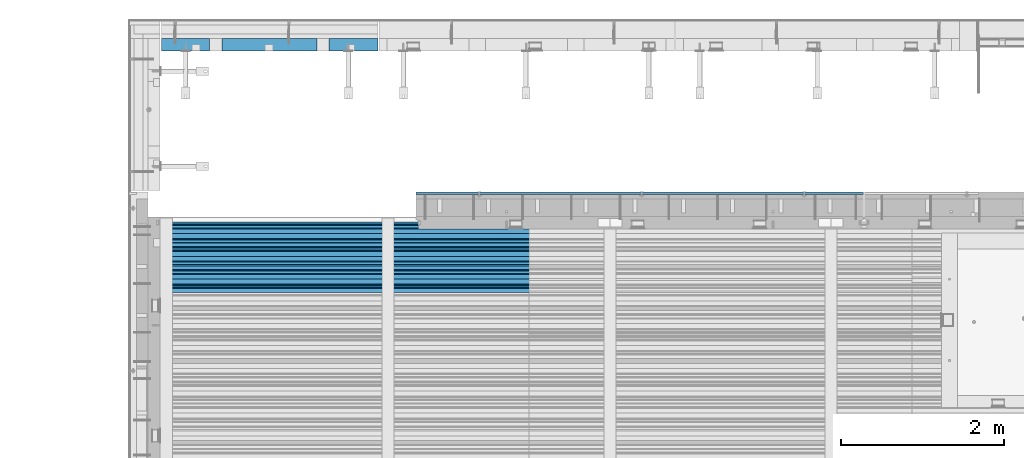
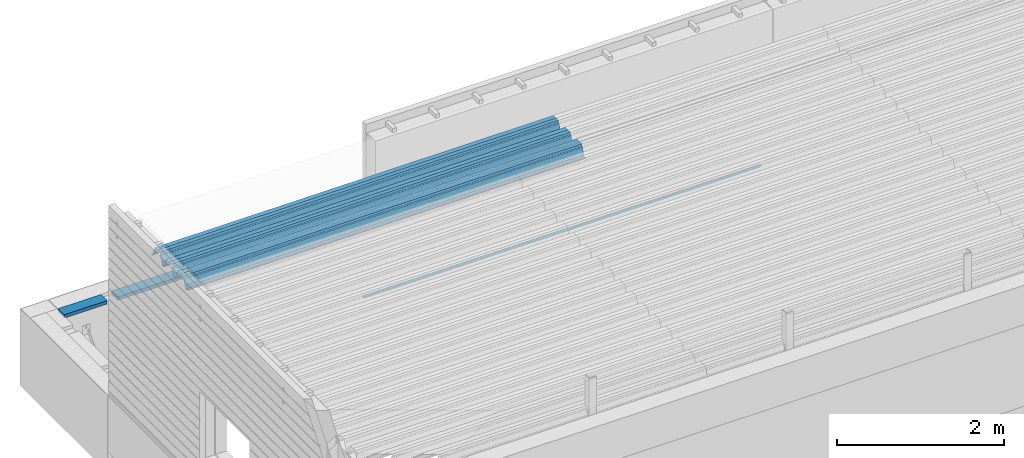
# One storey, part 35 of 153: 3 beams, 3 elements without a shape of their own.
"""IFC2X3 building model written with IfcOpenShell, lengths in millimetres."""

import ifcopenshell
import ifcopenshell.guid

model = None  # the IFC model being written
_history = None  # IfcOwnerHistory: only IFC2X3 demands one
_inside = {}  # id of a spatial element -> (the spatial element, [elements in it])
_under = {}  # id of a project, library or spatial element -> (it, [spatial elements below it])
_declared = {}  # id of a project -> (the project, [libraries it declares])
_typed = {}  # id of a type object -> (the type object, [elements of that type])
_made_of = {}  # id of a material, layer set ... -> (it, [elements and type objects made of it])


def new_model(schema):
    """Start an empty IFC model of exactly this schema.

    Asked for "IFC4X3", IfcOpenShell would pick the latest addendum, in which some entities
    have other attributes; the version numbers below select the first issue.
    IFC2X3 requires an IfcOwnerHistory on every rooted entity: one is made here for all.
    """
    global model, _history
    if schema == "IFC4X3":
        model = ifcopenshell.file(schema_version=(4, 3, 0, 0))
    else:
        model = ifcopenshell.file(schema=schema)
    _inside.clear()
    _under.clear()
    _declared.clear()
    _typed.clear()
    _made_of.clear()
    _history = None
    if model.schema == "IFC2X3":
        org = make("IfcOrganization", Name="unknown")
        user = make(
            "IfcPersonAndOrganization",
            ThePerson=make("IfcPerson", FamilyName="unknown"),
            TheOrganization=org,
        )
        app = make(
            "IfcApplication",
            ApplicationDeveloper=org,
            Version="unknown",
            ApplicationFullName="unknown",
            ApplicationIdentifier="unknown",
        )
        _history = make(
            "IfcOwnerHistory",
            OwningUser=user,
            OwningApplication=app,
            ChangeAction="ADDED",
            CreationDate=0,
        )
    return model


def make(cls, **values):
    """One entity of the class cls with the attributes given. An attribute that is None is left unset."""
    return model.create_entity(
        cls, **{name: value for name, value in values.items() if value is not None}
    )


def rooted(cls, **values):
    """An entity with a GlobalId (a new one), such as an element, a storey or a relation."""
    return make(cls, GlobalId=ifcopenshell.guid.new(), OwnerHistory=_history, **values)


def si_unit(unit_type, name, prefix=None):
    """IfcSIUnit, for example si_unit("LENGTHUNIT", "METRE", prefix="MILLI")."""
    return make("IfcSIUnit", UnitType=unit_type, Prefix=prefix, Name=name)


def assignment(units):
    """IfcUnitAssignment: the units of a project."""
    return None if units is None else make("IfcUnitAssignment", Units=units)


def point(xyz):
    """IfcCartesianPoint."""
    return None if xyz is None else make("IfcCartesianPoint", Coordinates=xyz)


def direction(xyz):
    """IfcDirection."""
    return None if xyz is None else make("IfcDirection", DirectionRatios=xyz)


def frame(location, z_axis=None, x_axis=None):
    """IfcAxis2Placement3D, a coordinate frame: its origin and axes. An axis left out is left unset."""
    return make(
        "IfcAxis2Placement3D",
        Location=point(location),
        Axis=direction(z_axis),
        RefDirection=direction(x_axis),
    )


def origin_with_axes():
    """The frame at (0, 0, 0) with the z axis (0, 0, 1) and the x axis (1, 0, 0) written out."""
    return frame((0.0, 0.0, 0.0), z_axis=(0.0, 0.0, 1.0), x_axis=(1.0, 0.0, 0.0))


def place(relative_to, where):
    """IfcLocalPlacement: puts the frame where relative to a parent placement (None: the world)."""
    return make(
        "IfcLocalPlacement", PlacementRelTo=relative_to, RelativePlacement=where
    )


def context(
    kind, dimensions, precision=None, world=None, true_north=None, identifier=None
):
    """IfcGeometricRepresentationContext, for example the 3D "Model" context."""
    return make(
        "IfcGeometricRepresentationContext",
        ContextIdentifier=identifier,
        ContextType=kind,
        CoordinateSpaceDimension=dimensions,
        Precision=precision,
        WorldCoordinateSystem=world,
        TrueNorth=true_north,
    )


def subcontext(parent, identifier, kind, view, scale=None):
    """IfcGeometricRepresentationSubContext, for example "Body" below "Model"."""
    return make(
        "IfcGeometricRepresentationSubContext",
        ContextIdentifier=identifier,
        ContextType=kind,
        ParentContext=parent,
        TargetScale=scale,
        TargetView=view,
    )


def project(units=None, contexts=None):
    """IfcProject with its units and contexts."""
    return rooted(
        "IfcProject",
        Name="project",
        RepresentationContexts=contexts,
        UnitsInContext=assignment(units),
    )


def spatial(cls, under=None, at=None, **own):
    """A site, building, storey or space (cls), placed at a placement, below another one or the project."""
    s = rooted(cls, ObjectPlacement=at, **own)
    if under is not None:
        _under.setdefault(under.id(), (under, []))[1].append(s)
    return s


def faces_of(points, faces, orient=None, outer=None):
    """IfcFace entities. A face is a list of loops; a loop is a list of indices into points, from 0.

    orient and outer hold one flag for each loop. By default every Orientation is true, the
    first loop of a face is its IfcFaceOuterBound and the others are IfcFaceBound.
    """
    made = []
    for i, loops in enumerate(faces):
        bounds = []
        for j, loop in enumerate(loops):
            is_outer = j == 0 if outer is None else outer[i][j]
            bounds.append(
                make(
                    "IfcFaceOuterBound" if is_outer else "IfcFaceBound",
                    Bound=make("IfcPolyLoop", Polygon=[points[k] for k in loop]),
                    Orientation=True if orient is None else orient[i][j],
                )
            )
        made.append(make("IfcFace", Bounds=bounds))
    return made


def faceted_brep(points, faces, orient=None, outer=None, voids=None):
    """IfcFacetedBrep: a solid bounded by flat faces; with voids (closed shells), ...WithVoids."""
    shared = [point(p) for p in points]
    hull = make("IfcClosedShell", CfsFaces=faces_of(shared, faces, orient, outer))
    if voids is None:
        return make("IfcFacetedBrep", Outer=hull)
    return make(
        "IfcFacetedBrepWithVoids",
        Outer=hull,
        Voids=[
            make(cls, CfsFaces=faces_of(shared, fs, o, b)) for cls, fs, o, b in voids
        ],
    )


def shape(context_of_items, identifier, shape_type, items):
    """IfcShapeRepresentation: the items that make up one representation, for example the "Body"."""
    return make(
        "IfcShapeRepresentation",
        ContextOfItems=context_of_items,
        RepresentationIdentifier=identifier,
        RepresentationType=shape_type,
        Items=items,
    )


def material(Name=None, Category=None):
    """IfcMaterial."""
    return make("IfcMaterial", Name=Name, Category=Category)


def made_of(thing, what):
    """Note that an element or type object is made of a material, layer set ...; save() writes the relation."""
    if what is not None:
        _made_of.setdefault(what.id(), (what, []))[1].append(thing)
    return thing


def type_object(cls, material=None, **own):
    """A type object (cls), such as IfcWallType, which elements share."""
    return made_of(rooted(cls, **own), material)


def element(
    cls,
    number,
    at=None,
    inside=None,
    cuts=None,
    type_object=None,
    material=None,
    context=None,
    identifier="Body",
    shape_type=None,
    held_by="IfcProductDefinitionShape",
    body=None,
    shapes=None,
    **own,
):
    """One element of the class cls, such as IfcWall. Its Tag is "e" and its number.

    at: its placement. inside: the storey or other place that contains it. cuts: it is an
    opening in that element (IfcRelVoidsElement). A single representation is given by context,
    identifier, shape_type and body (its items); several are given by shapes. held_by: the class
    of the entity that holds the representations. save() writes the other relations.
    """
    e = rooted(cls, Tag="e%d" % number, ObjectPlacement=at, **own)
    if body is not None:
        shapes = [shape(context, identifier, shape_type, body)]
    if shapes is not None:
        e.Representation = make(held_by, Representations=shapes)
    if inside is not None:
        _inside.setdefault(inside.id(), (inside, []))[1].append(e)
    if cuts is not None:
        rooted(
            "IfcRelVoidsElement", RelatingBuildingElement=cuts, RelatedOpeningElement=e
        )
    if type_object is not None:
        _typed.setdefault(type_object.id(), (type_object, []))[1].append(e)
    return made_of(e, material)


def aggregate(whole, parts):
    """IfcRelAggregates: a whole, such as a stair, and the parts it consists of."""
    return rooted("IfcRelAggregates", RelatingObject=whole, RelatedObjects=parts)


def save(model, path):
    """Write the relations noted so far, then the file.

    IfcRelAggregates (storeys below a building ...), IfcRelContainedInSpatialStructure (elements
    in a storey), IfcRelDefinesByType, IfcRelAssociatesMaterial and IfcRelDeclares: one each for
    every whole, place, type object, material and project.
    """
    for whole, parts in _under.values():
        aggregate(whole, parts)
    for where, things in _inside.values():
        rooted(
            "IfcRelContainedInSpatialStructure",
            RelatedElements=things,
            RelatingStructure=where,
        )
    for kind, things in _typed.values():
        rooted("IfcRelDefinesByType", RelatedObjects=things, RelatingType=kind)
    for what, things in _made_of.values():
        rooted("IfcRelAssociatesMaterial", RelatedObjects=things, RelatingMaterial=what)
    for by, libraries in _declared.values():
        rooted("IfcRelDeclares", RelatingContext=by, RelatedDefinitions=libraries)
    model.write(path)


model = new_model("IFC2X3")

# Units and contexts
model_context = context("Model", 3, precision=1e-05, world=origin_with_axes())
body_context = subcontext(model_context, "Body", "Model", "MODEL_VIEW")
ifc_project = project(units=[si_unit("LENGTHUNIT", "METRE", prefix="MILLI"), si_unit("AREAUNIT", "SQUARE_METRE"), si_unit("VOLUMEUNIT", "CUBIC_METRE"), si_unit("MASSUNIT", "GRAM", prefix="KILO"), si_unit("TIMEUNIT", "SECOND"), si_unit("PLANEANGLEUNIT", "RADIAN"), si_unit("SOLIDANGLEUNIT", "STERADIAN"), si_unit("THERMODYNAMICTEMPERATUREUNIT", "DEGREE_CELSIUS"), si_unit("LUMINOUSINTENSITYUNIT", "LUMEN")], contexts=[model_context])

# Site, building, storey
site_placement = place(None, origin_with_axes())
site = spatial("IfcSite", under=ifc_project, at=site_placement, CompositionType="ELEMENT")
building_placement = place(site_placement, origin_with_axes())
building = spatial("IfcBuilding", under=site, at=building_placement, CompositionType="ELEMENT")
storey_placement = place(building_placement, origin_with_axes())
storey = spatial("IfcBuildingStorey", under=building, at=storey_placement, Name="8", CompositionType="ELEMENT", Elevation=0.0)

# Assembly, beam
assembly_1_placement = place(storey_placement, origin_with_axes())
assembly_1 = element("IfcElementAssembly", 1, at=assembly_1_placement, inside=storey, AssemblyPlace="NOTDEFINED", PredefinedType="REINFORCEMENT_UNIT")
ifc_material_1 = material(Name="TIMBER")
beam_type_1 = type_object("IfcBeamType", PredefinedType="NOTDEFINED")
beam_1_placement = place(assembly_1_placement, frame((8015.0, 22695.0, 103545.0), z_axis=(0.0, 0.0, 1.0), x_axis=(1.0, 0.0, 0.0)))
beam_1 = element("IfcBeam", 2, at=beam_1_placement, type_object=beam_type_1, material=ifc_material_1, context=body_context, shape_type="Brep", body=[
    faceted_brep([(0.0, -75.0, -25.0), (1.81898940354586e-12, -75.0000000000009, 25.0), (1.81898940354586e-12, 75.0, 25.0), (0.0, 75.0, -25.0), (593.999676343074, -75.0, -25.0), (593.999676343074, -75.0, 25.0), (593.999640793072, 74.9998429442203, 25.0), (593.999640793072, 75.0, -25.0), (2063.99964079282, 74.9998784942218, 25.0), (2063.99964079282, 75.0, -25.0), (2063.99967634307, -75.0, -25.0), (2063.99967634307, -75.0, 25.0), (2662.5, -75.0, 25.0), (2662.5, -75.0, -25.0), (2662.5, 75.0, -25.0), (2662.5, 75.0, 25.0), (1913.99964079307, 74.9998429442203, 25.0), (1913.99967634307, -75.0, 25.0), (1913.99967634307, -75.0, -25.0), (1913.99964079307, 75.0, -25.0), (743.999640792823, 74.9998784942218, 25.0), (743.999640792823, 75.0, -25.0), (743.999676343068, -75.0, -25.0), (743.999676343068, -75.0, 25.0)], [[[0, 1, 2, 3]], [[1, 0, 4, 5]], [[2, 1, 5, 6]], [[3, 2, 6, 7]], [[0, 3, 7, 4]], [[6, 5, 4, 7]], [[8, 9, 10, 11]], [[12, 13, 14, 15]], [[12, 15, 8, 11]], [[13, 12, 11, 10]], [[14, 13, 10, 9]], [[15, 14, 9, 8]], [[16, 17, 18, 19]], [[20, 21, 22, 23]], [[21, 20, 16, 19]], [[22, 21, 19, 18]], [[23, 22, 18, 17]], [[20, 23, 17, 16]]]),
])
aggregate(assembly_1, [beam_1])

assembly_2_placement = place(storey_placement, origin_with_axes())
assembly_2 = element("IfcElementAssembly", 3, at=assembly_2_placement, inside=storey, AssemblyPlace="NOTDEFINED", PredefinedType="REINFORCEMENT_UNIT")
ifc_material_2 = material(Name="TIMBER/T24")
beam_type_2 = type_object("IfcBeamType", PredefinedType="NOTDEFINED")
beam_2_placement = place(assembly_2_placement, frame((11147.5, 20867.5, 103805.0), z_axis=(0.0, 1.0, 0.0), x_axis=(1.0, 0.0, 0.0)))
beam_2 = element("IfcBeam", 4, at=beam_2_placement, type_object=beam_type_2, material=ifc_material_2, context=body_context, shape_type="Brep", body=[
    faceted_brep([(5505.0, -6.35918695479631e-09, 12.4999999935681), (1.45519152283669e-11, -3.63797880709171e-12, 12.4999999999964), (0.0, -25.0, -12.5), (5505.0, -25.0, -12.5), (0.0, 25.0, -12.5), (0.0, 25.0, 12.5), (5505.0, 25.0, 12.5), (5505.0, 25.0, -12.5)], [[[0, 1, 2, 3]], [[4, 5, 6, 7]], [[7, 6, 0, 3]], [[4, 7, 3, 2]], [[5, 4, 2, 1]], [[6, 5, 1, 0]]]),
])
aggregate(assembly_2, [beam_2])

assembly_3_placement = place(storey_placement, origin_with_axes())
assembly_3 = element("IfcElementAssembly", 5, at=assembly_3_placement, inside=storey, Name="Steel Assembly", AssemblyPlace="NOTDEFINED", PredefinedType="RIGID_FRAME")
ifc_material_3 = material(Name="STEEL/S355J2")
beam_type_3 = type_object("IfcBeamType", Name="W", PredefinedType="NOTDEFINED")
beam_3_placement = place(assembly_3_placement, frame((13534.9999999929, 20081.9521353056, 105808.609793062), z_axis=(0.0, -0.0124990270013869, 0.999921884110963), x_axis=(-1.0, 3.00000001838171e-08, 0.0)))
beam_3 = element("IfcBeam", 6, at=beam_3_placement, type_object=beam_type_3, material=ifc_material_3, ObjectType="W", context=body_context, shape_type="Brep", body=[
    faceted_brep([(0.0, -412.839996337891, -77.0100021362159), (0.0, -409.160003662109, -77.0100021362014), (5530.0, -409.160003662109, -77.0100021362014), (5530.0, -412.839996337891, -77.0100021362159), (0.0, -408.070007324222, -73.4800033569045), (5530.0, -408.070007324222, -73.4800033569045), (0.0, -400.339996337894, -48.0600013732619), (5530.0, -400.339996337894, -48.0600013732619), (0.0, -399.459991455082, -46.5600013732619), (5530.0, -399.459991455082, -46.5600013732619), (0.0, -390.329986572269, -36.5499992370314), (5530.0, -390.329986572269, -36.5499992370314), (0.0, -389.19000244141, -34.6300010680861), (5530.0, -389.19000244141, -34.6300010680861), (0.0, -367.820007324222, 35.3400001526024), (5530.0, -367.820007324222, 35.3400001526024), (0.0, -366.989990234379, 36.8499984741502), (5530.0, -366.989990234379, 36.8499984741502), (0.0, -357.809997558597, 46.8600006103807), (5530.0, -357.809997558597, 46.8600006103807), (0.0, -356.720001220707, 48.7700004577782), (5530.0, -356.720001220707, 48.7700004577782), (0.0, -349.309997558594, 73.1500015258935), (5530.0, -349.309997558594, 73.1500015258935), (0.0, -347.850006103516, 75.2300033569481), (5530.0, -347.850006103516, 75.2300033569481), (0.0, -345.470001220707, 76.010002136245), (5530.0, -345.470001220707, 76.010002136245), (0.0, -305.480010986332, 76.010002136245), (5530.0, -305.480010986332, 76.010002136245), (0.0, -304.279998779301, 75.8000030517578), (5530.0, -304.279998779301, 75.8000030517578), (0.0, -291.679992675785, 71.6999969482567), (5530.0, -291.679992675785, 71.6999969482567), (0.0, -290.179992675789, 71.2300033569481), (5530.0, -290.179992675789, 71.2300033569481), (0.0, -288.720001220707, 71.6999969482567), (5530.0, -288.720001220707, 71.6999969482567), (0.0, -276.119995117191, 75.8000030517869), (5530.0, -276.119995117191, 75.8000030517869), (0.0, -274.929992675785, 76.010002136245), (5530.0, -274.929992675785, 76.010002136245), (0.0, -234.94000244141, 76.010002136245), (5530.0, -234.94000244141, 76.010002136245), (0.0, -232.550003051758, 75.2300033569627), (5530.0, -232.550003051758, 75.2300033569627), (0.0, -231.100006103519, 73.1500015258935), (5530.0, -231.100006103519, 73.1500015258935), (0.0, -223.679992675785, 48.7700004577782), (5530.0, -223.679992675785, 48.7700004577782), (0.0, -222.589996337894, 46.8600006103661), (5530.0, -222.589996337894, 46.8600006103661), (0.0, -213.410003662113, 36.8499984741502), (5530.0, -213.410003662113, 36.8499984741502), (0.0, -212.529998779301, 35.3400001526024), (5530.0, -212.529998779301, 35.3400001526024), (0.0, -191.160003662109, -34.6300010681007), (5530.0, -191.160003662109, -34.6300010681007), (0.0, -190.070007324222, -36.5499992370605), (5530.0, -190.070007324222, -36.5499992370605), (0.0, -180.940002441406, -46.560001373291), (5530.0, -180.940002441406, -46.560001373291), (0.0, -180.059997558597, -48.0600013732619), (5530.0, -180.059997558597, -48.0600013732619), (0.0, -172.330001831055, -73.480003356919), (5530.0, -172.330001831055, -73.480003356919), (0.0, -171.240005493168, -77.0100021362159), (5530.0, -171.240005493168, -77.0100021362159), (0.0, -129.330001831062, -77.0100021362014), (5530.0, -129.330001831062, -77.0100021362014), (0.0, -128.300003051761, -73.480003356919), (5530.0, -128.300003051761, -73.480003356919), (0.0, -120.51999664307, -48.0600013732765), (5530.0, -120.51999664307, -48.0600013732765), (0.0, -119.629997253418, -46.5600013732765), (5530.0, -119.629997253418, -46.5600013732765), (0.0, -110.500000000004, -36.5499992370314), (5530.0, -110.500000000004, -36.5499992370314), (0.0, -109.419998168949, -34.6300010680861), (5530.0, -109.419998168949, -34.6300010680861), (0.0, -88.0500030517615, 35.3400001526024), (5530.0, -88.0500030517615, 35.3400001526024), (0.0, -87.160003662113, 36.8499984741356), (5530.0, -87.160003662113, 36.8499984741356), (0.0, -78.0400009155273, 46.8600006103807), (5530.0, -78.0400009155273, 46.8600006103807), (0.0, -76.8899993896557, 48.7700004577782), (5530.0, -76.8899993896557, 48.7700004577782), (0.0, -69.4800033569336, 73.1500015258935), (5530.0, -69.4800033569336, 73.1500015258935), (0.0, -68.0299987793042, 75.2300033569336), (5530.0, -68.0299987793042, 75.2300033569336), (0.0, -65.6399993896521, 76.010002136245), (5530.0, -65.6399993896521, 76.010002136245), (0.0, -25.6499996185375, 76.0100021362596), (5530.0, -25.6499996185375, 76.0100021362596), (0.0, -24.5100002288891, 75.8000030517724), (5530.0, -24.5100002288891, 75.8000030517724), (0.0, -11.8500003814697, 71.6999969482567), (5530.0, -11.8500003814697, 71.6999969482567), (0.0, -10.3999996185339, 71.2300033569481), (5530.0, -10.3999996185339, 71.2300033569481), (0.0, -8.89999961853391, 71.6999969482567), (5530.0, -8.89999961853391, 71.6999969482567), (0.0, 3.71000003814333, 75.8000030517724), (5530.0, 3.71000003814333, 75.8000030517724), (0.0, 4.90000009536379, 76.0100021362596), (5530.0, 4.90000009536379, 76.0100021362596), (0.0, 44.8899993896484, 76.010002136245), (5530.0, 44.8899993896484, 76.010002136245), (0.0, 47.2799987792932, 75.2300033569481), (5530.0, 47.2799987792932, 75.2300033569481), (0.0, 48.6800003051721, 73.1500015258935), (5530.0, 48.6800003051721, 73.1500015258935), (0.0, 56.1500015258753, 48.7700004577782), (5530.0, 56.1500015258753, 48.7700004577782), (0.0, 57.2400016784632, 46.8600006103807), (5530.0, 57.2400016784632, 46.8600006103807), (0.0, 66.3700027465784, 36.8499984741211), (5530.0, 66.3700027465784, 36.8499984741211), (0.0, 67.2499999999964, 35.3400001526024), (5530.0, 67.2499999999964, 35.3400001526024), (0.0, 88.6200027465748, -34.6300010681007), (5530.0, 88.6200027465748, -34.6300010681007), (0.0, 89.709999084469, -36.549999237046), (5530.0, 89.709999084469, -36.549999237046), (0.0, 98.8899993896412, -46.5600013732765), (5530.0, 98.8899993896412, -46.5600013732765), (0.0, 99.7699966430628, -48.0600013732765), (5530.0, 99.7699966430628, -48.0600013732765), (0.0, 107.499999999996, -73.4800033569336), (5530.0, 107.499999999996, -73.4800033569336), (0.0, 108.589996337887, -77.0100021362014), (5530.0, 108.589996337887, -77.0100021362014), (0.0, 112.269996643063, -77.0100021362159), (5530.0, 112.269996643063, -77.0100021362159), (0.0, 146.759994506836, -77.0100021362159), (5530.0, 146.759994506836, -77.0100021362159), (0.0, 150.440002441403, -77.0100021362159), (5530.0, 150.440002441403, -77.0100021362159), (0.0, 151.529998779297, -73.480003356919), (5530.0, 151.529998779297, -73.480003356919), (0.0, 159.30999755859, -48.0600013732765), (5530.0, 159.30999755859, -48.0600013732765), (0.0, 160.190002441406, -46.5600013732619), (5530.0, 160.190002441406, -46.5600013732619), (0.0, 169.320007324215, -36.549999237046), (5530.0, 169.320007324215, -36.549999237046), (0.0, 170.410003662106, -34.6300010680861), (5530.0, 170.410003662106, -34.6300010680861), (0.0, 191.779998779293, 35.3400001526024), (5530.0, 191.779998779293, 35.3400001526024), (0.0, 192.660003662109, 36.8499984741502), (5530.0, 192.660003662109, 36.8499984741502), (0.0, 201.789993286129, 46.8600006103661), (5530.0, 201.789993286129, 46.8600006103661), (0.0, 202.880004882809, 48.7700004577637), (5530.0, 202.880004882809, 48.7700004577637), (0.0, 210.350006103512, 73.150001525908), (5530.0, 210.350006103512, 73.150001525908), (0.0, 211.800003051754, 75.2300033569481), (5530.0, 211.800003051754, 75.2300033569481), (0.0, 214.190002441406, 76.010002136245), (5530.0, 214.190002441406, 76.010002136245), (0.0, 254.179992675778, 76.010002136245), (5530.0, 254.179992675778, 76.010002136245), (0.0, 255.320007324215, 75.8000030517869), (5530.0, 255.320007324215, 75.8000030517869), (0.0, 267.980010986324, 71.6999969482713), (5530.0, 267.980010986324, 71.6999969482713), (0.0, 269.429992675778, 71.2300033569481), (5530.0, 269.429992675778, 71.2300033569481), (0.0, 270.880004882809, 71.6999969482567), (5530.0, 270.880004882809, 71.6999969482567), (0.0, 283.540008544918, 75.8000030517869), (5530.0, 283.540008544918, 75.8000030517869), (0.0, 284.679992675778, 76.010002136245), (5530.0, 284.679992675778, 76.010002136245), (0.0, 324.670013427731, 76.010002136245), (5530.0, 324.670013427731, 76.010002136245), (0.0, 327.049987792969, 75.2300033569627), (5530.0, 327.049987792969, 75.2300033569627), (0.0, 328.510009765625, 73.1500015258789), (5530.0, 328.510009765625, 73.1500015258789), (0.0, 335.980010986324, 48.7700004577782), (5530.0, 335.980010986324, 48.7700004577782), (0.0, 337.05999755859, 46.8600006103661), (5530.0, 337.05999755859, 46.8600006103661), (0.0, 346.190002441399, 36.8499984741356), (5530.0, 346.190002441399, 36.8499984741356), (0.0, 347.079986572266, 35.3400001526024), (5530.0, 347.079986572266, 35.3400001526024), (0.0, 368.450012207028, -34.6300010680861), (5530.0, 368.450012207028, -34.6300010680861), (0.0, 369.529998779293, -36.5499992370314), (5530.0, 369.529998779293, -36.5499992370314), (0.0, 378.660003662106, -46.5600013732619), (5530.0, 378.660003662106, -46.5600013732619), (0.0, 379.540008544918, -48.0600013732619), (5530.0, 379.540008544918, -48.0600013732619), (0.0, 387.329986572262, -73.480003356919), (5530.0, 387.329986572262, -73.480003356919), (0.0, 388.410003662109, -77.0100021362159), (5530.0, 388.410003662109, -77.0100021362159), (0.0, 392.100006103512, -77.0100021362159), (5530.0, 392.100006103512, -77.0100021362159), (0.0, 426.589996337887, -77.0100021362159), (5530.0, 426.589996337887, -77.0100021362159), (0.0, 430.269989013668, -77.0100021362159), (5530.0, 430.269989013668, -77.0100021362159), (0.0, 431.359985351559, -73.4800033569045), (5530.0, 431.359985351559, -73.4800033569045), (0.0, 433.179992675778, -67.5699996948097), (5530.0, 433.179992675778, -67.5699996948097), (0.0, 432.220001220699, -67.2699966430373), (5530.0, 432.220001220699, -67.2699966430373), (0.0, 430.410003662106, -73.1800003051612), (5530.0, 430.410003662106, -73.1800003051612), (0.0, 429.529998779293, -76.0100021362159), (5530.0, 429.529998779293, -76.0100021362159), (0.0, 426.589996337891, -76.0100021362159), (5530.0, 426.589996337891, -76.0100021362159), (0.0, 392.100006103512, -76.0100021362159), (5530.0, 392.100006103512, -76.0100021362159), (0.0, 389.149993896481, -76.0100021362014), (5530.0, 389.149993896481, -76.0100021362014), (0.0, 388.279998779293, -73.1800003051467), (5530.0, 388.279998779293, -73.1800003051467), (0.0, 380.470001220699, -47.659999847383), (5530.0, 380.470001220699, -47.659999847383), (0.0, 379.470001220699, -45.9599990844436), (5530.0, 379.470001220699, -45.9599990844436), (0.0, 370.350006103512, -35.9599990844581), (5530.0, 370.350006103512, -35.9599990844581), (0.0, 369.369995117184, -34.2299995422218), (5530.0, 369.369995117184, -34.2299995422218), (0.0, 347.999999999996, 35.7500000000146), (5530.0, 347.999999999996, 35.7500000000146), (0.0, 346.999999999996, 37.4399986267235), (5530.0, 346.999999999996, 37.4399986267235), (0.0, 337.880004882809, 47.450000762954), (5530.0, 337.880004882809, 47.450000762954), (0.0, 336.899993896481, 49.1699981689453), (5530.0, 336.899993896481, 49.1699981689453), (0.0, 329.420013427731, 73.5999984741356), (5530.0, 329.420013427731, 73.5999984741356), (0.0, 327.679992675781, 76.0699996948533), (5530.0, 327.679992675781, 76.0699996948533), (0.0, 324.829986572262, 77.010002136245), (5530.0, 324.829986572262, 77.010002136245), (0.0, 284.589996337887, 77.010002136245), (5530.0, 284.589996337887, 77.010002136245), (0.0, 283.290008544922, 76.769996643081), (5530.0, 283.290008544922, 76.769996643081), (0.0, 270.570007324215, 72.6500015258935), (5530.0, 270.570007324215, 72.6500015258935), (0.0, 269.429992675781, 72.2799987793114), (5530.0, 269.429992675781, 72.2799987793114), (0.0, 268.279998779293, 72.650001525908), (5530.0, 268.279998779293, 72.650001525908), (0.0, 255.570007324219, 76.769996643081), (5530.0, 255.570007324219, 76.769996643081), (0.0, 254.270004272461, 77.0100021362596), (5530.0, 254.270004272461, 77.0100021362596), (0.0, 214.029998779293, 77.0100021362596), (5530.0, 214.029998779293, 77.0100021362596), (0.0, 211.179992675781, 76.0699996948388), (5530.0, 211.179992675781, 76.0699996948388), (0.0, 209.440002441403, 73.5999984741356), (5530.0, 209.440002441403, 73.5999984741356), (0.0, 201.960006713864, 49.1699981689599), (5530.0, 201.960006713864, 49.1699981689599), (0.0, 200.979995727532, 47.450000762954), (5530.0, 200.979995727532, 47.450000762954), (0.0, 191.850006103508, 37.4399986267235), (5530.0, 191.850006103508, 37.4399986267235), (0.0, 190.860000610352, 35.7500000000146), (5530.0, 190.860000610352, 35.7500000000146), (0.0, 169.49000549316, -34.2299995422218), (5530.0, 169.49000549316, -34.2299995422218), (0.0, 168.509994506832, -35.9599990844581), (5530.0, 168.509994506832, -35.9599990844581), (0.0, 159.380004882805, -45.9599990844436), (5530.0, 159.380004882805, -45.9599990844436), (0.0, 158.389999389645, -47.6599998473976), (5530.0, 158.389999389645, -47.6599998473976), (0.0, 150.580001831051, -73.1800003051612), (5530.0, 150.580001831051, -73.1800003051612), (0.0, 149.710006713864, -76.0100021362159), (5530.0, 149.710006713864, -76.0100021362159), (0.0, 146.759994506836, -76.0100021362159), (5530.0, 146.759994506836, -76.0100021362159), (0.0, 112.269996643063, -76.0100021362159), (5530.0, 112.269996643063, -76.0100021362159), (0.0, 109.319999694821, -76.0100021362159), (5530.0, 109.319999694821, -76.0100021362159), (0.0, 108.449996948239, -73.1900024413917), (5530.0, 108.449996948239, -73.1900024413917), (0.0, 100.690002441406, -47.659999847383), (5530.0, 100.690002441406, -47.659999847383), (0.0, 99.6999969482386, -45.9599990844581), (5530.0, 99.6999969482386, -45.9599990844581), (0.0, 90.5199966430664, -35.9599990844581), (5530.0, 90.5199966430664, -35.9599990844581), (0.0, 89.5400009155273, -34.2299995422218), (5530.0, 89.5400009155273, -34.2299995422218), (0.0, 68.1699981689417, 35.7500000000146), (5530.0, 68.1699981689417, 35.7500000000146), (0.0, 67.1699981689417, 37.4399986267235), (5530.0, 67.1699981689417, 37.4399986267235), (0.0, 58.0499992370569, 47.4500007629686), (5530.0, 58.0499992370569, 47.4500007629686), (0.0, 57.0699996948206, 49.1699981689599), (5530.0, 57.0699996948206, 49.1699981689599), (0.0, 49.5900001525843, 73.5899963379052), (5530.0, 49.5900001525843, 73.5899963379052), (0.0, 47.9099998474085, 76.0699996948388), (5530.0, 47.9099998474085, 76.0699996948388), (0.0, 45.0499992370569, 77.010002136245), (5530.0, 45.0499992370569, 77.010002136245), (0.0, 4.82000017165774, 77.010002136245), (5530.0, 4.82000017165774, 77.010002136245), (0.0, 3.47000002860659, 76.7699966430955), (5530.0, 3.47000002860659, 76.7699966430955), (0.0, -9.19999980926514, 72.6500015258935), (5530.0, -9.19999980926514, 72.6500015258935), (0.0, -10.3900003433264, 72.2799987792969), (5530.0, -10.3900003433264, 72.2799987792969), (0.0, -11.5399999618567, 72.6500015258935), (5530.0, -11.5399999618567, 72.6500015258935), (0.0, -24.2600002288855, 76.769996643081), (5530.0, -24.2600002288855, 76.769996643081), (0.0, -25.559999465946, 77.0100021362596), (5530.0, -25.559999465946, 77.0100021362596), (0.0, -65.8000030517615, 77.0100021362596), (5530.0, -65.8000030517615, 77.0100021362596), (0.0, -68.6500015258862, 76.0699996948533), (5530.0, -68.6500015258862, 76.0699996948533), (0.0, -70.3899993896521, 73.5999984741356), (5530.0, -70.3899993896521, 73.5999984741356), (0.0, -77.8199996948242, 49.1800003051903), (5530.0, -77.8199996948242, 49.1800003051903), (0.0, -78.8399963378943, 47.450000762954), (5530.0, -78.8399963378943, 47.450000762954), (0.0, -87.9700012207031, 37.4399986267235), (5530.0, -87.9700012207031, 37.4399986267235), (0.0, -88.9700012207068, 35.7500000000146), (5530.0, -88.9700012207068, 35.7500000000146), (0.0, -110.339996337894, -34.2299995422218), (5530.0, -110.339996337894, -34.2299995422218), (0.0, -111.319999694828, -35.9599990844581), (5530.0, -111.319999694828, -35.9599990844581), (0.0, -120.440002441406, -45.9599990844436), (5530.0, -120.440002441406, -45.9599990844436), (0.0, -121.44000244141, -47.6599998473976), (5530.0, -121.44000244141, -47.6599998473976), (0.0, -129.250000000004, -73.1900024413771), (5530.0, -129.250000000004, -73.1900024413771), (0.0, -130.080001831062, -76.0100021362159), (5530.0, -130.080001831062, -76.0100021362159), (0.0, -170.5, -76.0100021362014), (5530.0, -170.5, -76.0100021362014), (0.0, -171.380004882816, -73.1900024413917), (5530.0, -171.380004882816, -73.1900024413917), (0.0, -179.139999389652, -47.6599998473976), (5530.0, -179.139999389652, -47.6599998473976), (0.0, -180.130004882816, -45.9599990844581), (5530.0, -180.130004882816, -45.9599990844581), (0.0, -189.259994506836, -35.9599990844581), (5530.0, -189.259994506836, -35.9599990844581), (0.0, -190.240005493168, -34.2299995422218), (5530.0, -190.240005493168, -34.2299995422218), (0.0, -211.610000610355, 35.7500000000146), (5530.0, -211.610000610355, 35.7500000000146), (0.0, -212.600006103519, 37.4399986267381), (5530.0, -212.600006103519, 37.4399986267381), (0.0, -221.779998779301, 47.450000762954), (5530.0, -221.779998779301, 47.450000762954), (0.0, -222.75999450684, 49.1699981689599), (5530.0, -222.75999450684, 49.1699981689599), (0.0, -230.190002441406, 73.5999984741356), (5530.0, -230.190002441406, 73.5999984741356), (0.0, -231.919998168945, 76.0699996948388), (5530.0, -231.919998168945, 76.0699996948388), (0.0, -234.779998779301, 77.010002136245), (5530.0, -234.779998779301, 77.010002136245), (0.0, -275.010009765629, 77.010002136245), (5530.0, -275.010009765629, 77.010002136245), (0.0, -276.359985351563, 76.769996643081), (5530.0, -276.359985351563, 76.769996643081), (0.0, -289.029998779297, 72.6500015258789), (5530.0, -289.029998779297, 72.6500015258789), (0.0, -290.179992675785, 72.2799987793114), (5530.0, -290.179992675785, 72.2799987793114), (0.0, -291.380004882816, 72.650001525908), (5530.0, -291.380004882816, 72.650001525908), (0.0, -304.040008544926, 76.769996643081), (5530.0, -304.040008544926, 76.769996643081), (0.0, -305.390014648441, 77.010002136245), (5530.0, -305.390014648441, 77.010002136245), (0.0, -345.63000488282, 77.0100021362596), (5530.0, -345.63000488282, 77.0100021362596), (0.0, -348.480010986332, 76.0699996948388), (5530.0, -348.480010986332, 76.0699996948388), (0.0, -350.220001220707, 73.5999984741356), (5530.0, -350.220001220707, 73.5999984741356), (0.0, -357.649993896492, 49.1699981689599), (5530.0, -357.649993896492, 49.1699981689599), (0.0, -358.63000488282, 47.450000762954), (5530.0, -358.63000488282, 47.450000762954), (0.0, -367.809997558594, 37.4300003051903), (5530.0, -367.809997558594, 37.4300003051903), (0.0, -368.750000000004, 35.7299995422654), (5530.0, -368.750000000004, 35.7299995422654), (0.0, -390.109985351566, -34.2200012207031), (5530.0, -390.109985351566, -34.2200012207031), (0.0, -391.140014648441, -35.9500007629249), (5530.0, -391.140014648441, -35.9500007629249), (0.0, -400.269989013676, -45.9599990844436), (5530.0, -400.269989013676, -45.9599990844436), (0.0, -401.269989013672, -47.6599998473976), (5530.0, -401.269989013672, -47.6599998473976), (0.0, -409.029998779297, -73.1900024413917), (5530.0, -409.029998779297, -73.1900024413917), (0.0, -409.899993896488, -76.0100021362159), (5530.0, -409.899993896488, -76.0100021362159), (0.0, -412.839996337891, -76.0100021362159), (5530.0, -412.839996337891, -76.0100021362159), (0.0, -433.179992675785, -76.0100021362159), (5530.0, -433.179992675785, -76.0100021362159), (0.0, -433.179992675785, -77.0100021362159), (5530.0, -433.179992675785, -77.0100021362159)], [[[0, 1, 2, 3]], [[1, 4, 5, 2]], [[4, 6, 7, 5]], [[6, 8, 9, 7]], [[8, 10, 11, 9]], [[10, 12, 13, 11]], [[12, 14, 15, 13]], [[14, 16, 17, 15]], [[16, 18, 19, 17]], [[18, 20, 21, 19]], [[20, 22, 23, 21]], [[22, 24, 25, 23]], [[24, 26, 27, 25]], [[26, 28, 29, 27]], [[28, 30, 31, 29]], [[30, 32, 33, 31]], [[32, 34, 35, 33]], [[34, 36, 37, 35]], [[36, 38, 39, 37]], [[38, 40, 41, 39]], [[40, 42, 43, 41]], [[42, 44, 45, 43]], [[44, 46, 47, 45]], [[46, 48, 49, 47]], [[48, 50, 51, 49]], [[50, 52, 53, 51]], [[52, 54, 55, 53]], [[54, 56, 57, 55]], [[56, 58, 59, 57]], [[58, 60, 61, 59]], [[60, 62, 63, 61]], [[62, 64, 65, 63]], [[64, 66, 67, 65]], [[66, 68, 69, 67]], [[68, 70, 71, 69]], [[70, 72, 73, 71]], [[72, 74, 75, 73]], [[74, 76, 77, 75]], [[76, 78, 79, 77]], [[78, 80, 81, 79]], [[80, 82, 83, 81]], [[82, 84, 85, 83]], [[84, 86, 87, 85]], [[86, 88, 89, 87]], [[88, 90, 91, 89]], [[90, 92, 93, 91]], [[92, 94, 95, 93]], [[94, 96, 97, 95]], [[96, 98, 99, 97]], [[98, 100, 101, 99]], [[100, 102, 103, 101]], [[102, 104, 105, 103]], [[104, 106, 107, 105]], [[106, 108, 109, 107]], [[108, 110, 111, 109]], [[110, 112, 113, 111]], [[112, 114, 115, 113]], [[114, 116, 117, 115]], [[116, 118, 119, 117]], [[118, 120, 121, 119]], [[120, 122, 123, 121]], [[122, 124, 125, 123]], [[124, 126, 127, 125]], [[126, 128, 129, 127]], [[128, 130, 131, 129]], [[130, 132, 133, 131]], [[132, 134, 135, 133]], [[134, 136, 137, 135]], [[136, 138, 139, 137]], [[138, 140, 141, 139]], [[140, 142, 143, 141]], [[142, 144, 145, 143]], [[144, 146, 147, 145]], [[146, 148, 149, 147]], [[148, 150, 151, 149]], [[150, 152, 153, 151]], [[152, 154, 155, 153]], [[154, 156, 157, 155]], [[156, 158, 159, 157]], [[158, 160, 161, 159]], [[160, 162, 163, 161]], [[162, 164, 165, 163]], [[164, 166, 167, 165]], [[166, 168, 169, 167]], [[168, 170, 171, 169]], [[170, 172, 173, 171]], [[172, 174, 175, 173]], [[174, 176, 177, 175]], [[176, 178, 179, 177]], [[178, 180, 181, 179]], [[180, 182, 183, 181]], [[182, 184, 185, 183]], [[184, 186, 187, 185]], [[186, 188, 189, 187]], [[188, 190, 191, 189]], [[190, 192, 193, 191]], [[192, 194, 195, 193]], [[194, 196, 197, 195]], [[196, 198, 199, 197]], [[198, 200, 201, 199]], [[200, 202, 203, 201]], [[202, 204, 205, 203]], [[204, 206, 207, 205]], [[206, 208, 209, 207]], [[208, 210, 211, 209]], [[210, 212, 213, 211]], [[212, 214, 215, 213]], [[214, 216, 217, 215]], [[216, 218, 219, 217]], [[218, 220, 221, 219]], [[220, 222, 223, 221]], [[222, 224, 225, 223]], [[224, 226, 227, 225]], [[226, 228, 229, 227]], [[228, 230, 231, 229]], [[230, 232, 233, 231]], [[232, 234, 235, 233]], [[234, 236, 237, 235]], [[236, 238, 239, 237]], [[238, 240, 241, 239]], [[240, 242, 243, 241]], [[242, 244, 245, 243]], [[244, 246, 247, 245]], [[246, 248, 249, 247]], [[248, 250, 251, 249]], [[250, 252, 253, 251]], [[252, 254, 255, 253]], [[254, 256, 257, 255]], [[256, 258, 259, 257]], [[258, 260, 261, 259]], [[260, 262, 263, 261]], [[262, 264, 265, 263]], [[264, 266, 267, 265]], [[266, 268, 269, 267]], [[268, 270, 271, 269]], [[270, 272, 273, 271]], [[272, 274, 275, 273]], [[274, 276, 277, 275]], [[276, 278, 279, 277]], [[278, 280, 281, 279]], [[280, 282, 283, 281]], [[282, 284, 285, 283]], [[284, 286, 287, 285]], [[286, 288, 289, 287]], [[288, 290, 291, 289]], [[290, 292, 293, 291]], [[292, 294, 295, 293]], [[294, 296, 297, 295]], [[296, 298, 299, 297]], [[298, 300, 301, 299]], [[300, 302, 303, 301]], [[302, 304, 305, 303]], [[304, 306, 307, 305]], [[306, 308, 309, 307]], [[308, 310, 311, 309]], [[310, 312, 313, 311]], [[312, 314, 315, 313]], [[314, 316, 317, 315]], [[316, 318, 319, 317]], [[318, 320, 321, 319]], [[320, 322, 323, 321]], [[322, 324, 325, 323]], [[324, 326, 327, 325]], [[326, 328, 329, 327]], [[328, 330, 331, 329]], [[330, 332, 333, 331]], [[332, 334, 335, 333]], [[334, 336, 337, 335]], [[336, 338, 339, 337]], [[338, 340, 341, 339]], [[340, 342, 343, 341]], [[342, 344, 345, 343]], [[344, 346, 347, 345]], [[346, 348, 349, 347]], [[348, 350, 351, 349]], [[350, 352, 353, 351]], [[352, 354, 355, 353]], [[354, 356, 357, 355]], [[356, 358, 359, 357]], [[358, 360, 361, 359]], [[360, 362, 363, 361]], [[362, 364, 365, 363]], [[364, 366, 367, 365]], [[366, 368, 369, 367]], [[368, 370, 371, 369]], [[370, 372, 373, 371]], [[372, 374, 375, 373]], [[374, 376, 377, 375]], [[376, 378, 379, 377]], [[378, 380, 381, 379]], [[380, 382, 383, 381]], [[382, 384, 385, 383]], [[384, 386, 387, 385]], [[386, 388, 389, 387]], [[388, 390, 391, 389]], [[390, 392, 393, 391]], [[392, 394, 395, 393]], [[394, 396, 397, 395]], [[396, 398, 399, 397]], [[398, 400, 401, 399]], [[400, 402, 403, 401]], [[402, 404, 405, 403]], [[404, 406, 407, 405]], [[406, 408, 409, 407]], [[408, 410, 411, 409]], [[410, 412, 413, 411]], [[412, 414, 415, 413]], [[414, 416, 417, 415]], [[416, 418, 419, 417]], [[418, 420, 421, 419]], [[420, 422, 423, 421]], [[422, 424, 425, 423]], [[424, 426, 427, 425]], [[426, 428, 429, 427]], [[428, 430, 431, 429]], [[430, 0, 3, 431]], [[5, 7, 9, 11, 13, 15, 17, 19, 21, 23, 25, 27, 29, 31, 33, 35, 37, 39, 41, 43, 45, 47, 49, 51, 53, 55, 57, 59, 61, 63, 65, 67, 69, 71, 73, 75, 77, 79, 81, 83, 85, 87, 89, 91, 93, 95, 97, 99, 101, 103, 105, 107, 109, 111, 113, 115, 117, 119, 121, 123, 125, 127, 129, 131, 133, 135, 137, 139, 141, 143, 145, 147, 149, 151, 153, 155, 157, 159, 161, 163, 165, 167, 169, 171, 173, 175, 177, 179, 181, 183, 185, 187, 189, 191, 193, 195, 197, 199, 201, 203, 205, 207, 209, 211, 213, 215, 217, 219, 221, 223, 225, 227, 229, 231, 233, 235, 237, 239, 241, 243, 245, 247, 249, 251, 253, 255, 257, 259, 261, 263, 265, 267, 269, 271, 273, 275, 277, 279, 281, 283, 285, 287, 289, 291, 293, 295, 297, 299, 301, 303, 305, 307, 309, 311, 313, 315, 317, 319, 321, 323, 325, 327, 329, 331, 333, 335, 337, 339, 341, 343, 345, 347, 349, 351, 353, 355, 357, 359, 361, 363, 365, 367, 369, 371, 373, 375, 377, 379, 381, 383, 385, 387, 389, 391, 393, 395, 397, 399, 401, 403, 405, 407, 409, 411, 413, 415, 417, 419, 421, 423, 425, 427, 429, 431, 3, 2]], [[430, 428, 426, 424, 422, 420, 418, 416, 414, 412, 410, 408, 406, 404, 402, 400, 398, 396, 394, 392, 390, 388, 386, 384, 382, 380, 378, 376, 374, 372, 370, 368, 366, 364, 362, 360, 358, 356, 354, 352, 350, 348, 346, 344, 342, 340, 338, 336, 334, 332, 330, 328, 326, 324, 322, 320, 318, 316, 314, 312, 310, 308, 306, 304, 302, 300, 298, 296, 294, 292, 290, 288, 286, 284, 282, 280, 278, 276, 274, 272, 270, 268, 266, 264, 262, 260, 258, 256, 254, 252, 250, 248, 246, 244, 242, 240, 238, 236, 234, 232, 230, 228, 226, 224, 222, 220, 218, 216, 214, 212, 210, 208, 206, 204, 202, 200, 198, 196, 194, 192, 190, 188, 186, 184, 182, 180, 178, 176, 174, 172, 170, 168, 166, 164, 162, 160, 158, 156, 154, 152, 150, 148, 146, 144, 142, 140, 138, 136, 134, 132, 130, 128, 126, 124, 122, 120, 118, 116, 114, 112, 110, 108, 106, 104, 102, 100, 98, 96, 94, 92, 90, 88, 86, 84, 82, 80, 78, 76, 74, 72, 70, 68, 66, 64, 62, 60, 58, 56, 54, 52, 50, 48, 46, 44, 42, 40, 38, 36, 34, 32, 30, 28, 26, 24, 22, 20, 18, 16, 14, 12, 10, 8, 6, 4, 1, 0]]]),
])
aggregate(assembly_3, [beam_3])

save(model, "model.ifc")
